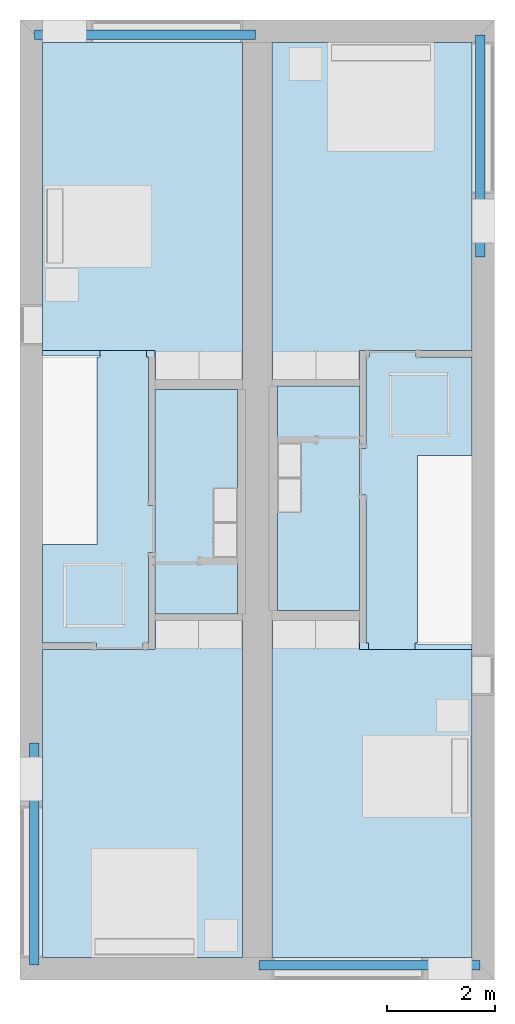
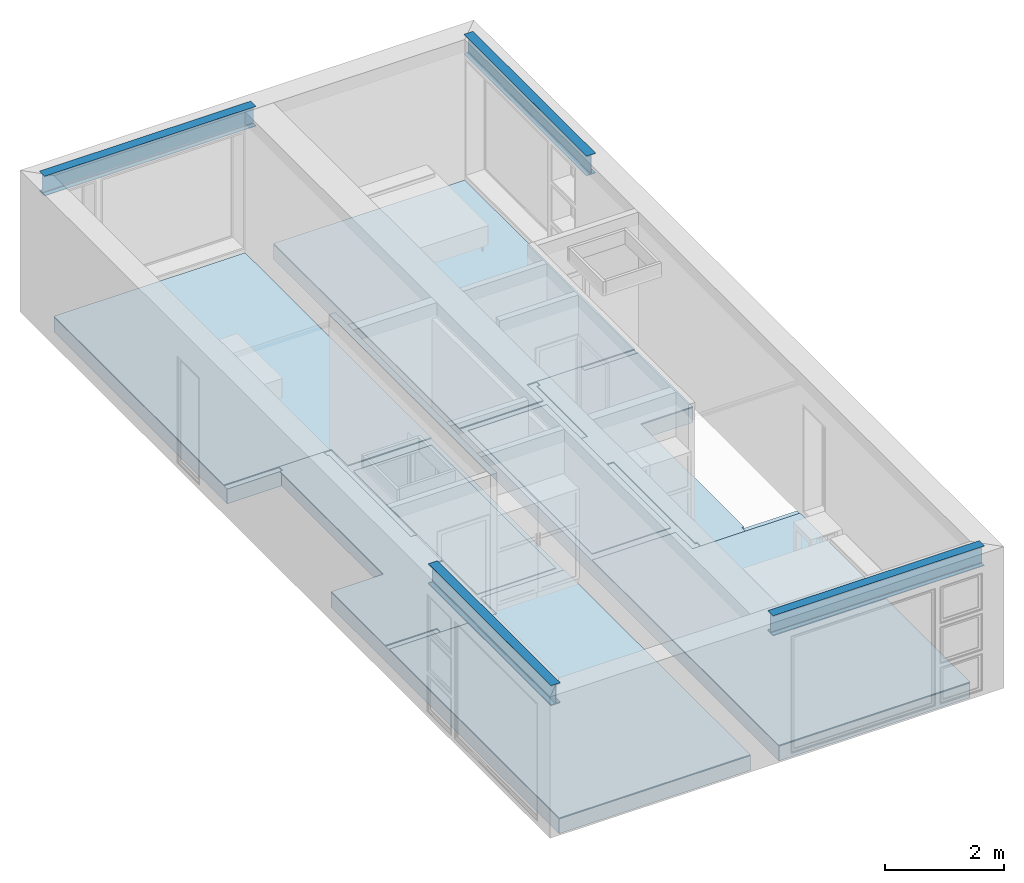
# One storey, part 1 of 14: 10 slabs, 4 beams.
"""IFC2X3 building model written with IfcOpenShell, lengths in metres."""

import ifcopenshell
import ifcopenshell.guid

model = None  # the IFC model being written
_history = None  # IfcOwnerHistory: only IFC2X3 demands one
_inside = {}  # id of a spatial element -> (the spatial element, [elements in it])
_under = {}  # id of a project, library or spatial element -> (it, [spatial elements below it])
_declared = {}  # id of a project -> (the project, [libraries it declares])
_typed = {}  # id of a type object -> (the type object, [elements of that type])
_made_of = {}  # id of a material, layer set ... -> (it, [elements and type objects made of it])


def new_model(schema):
    """Start an empty IFC model of exactly this schema.

    Asked for "IFC4X3", IfcOpenShell would pick the latest addendum, in which some entities
    have other attributes; the version numbers below select the first issue.
    IFC2X3 requires an IfcOwnerHistory on every rooted entity: one is made here for all.
    """
    global model, _history
    if schema == "IFC4X3":
        model = ifcopenshell.file(schema_version=(4, 3, 0, 0))
    else:
        model = ifcopenshell.file(schema=schema)
    _inside.clear()
    _under.clear()
    _declared.clear()
    _typed.clear()
    _made_of.clear()
    _history = None
    if model.schema == "IFC2X3":
        org = make("IfcOrganization", Name="unknown")
        user = make(
            "IfcPersonAndOrganization",
            ThePerson=make("IfcPerson", FamilyName="unknown"),
            TheOrganization=org,
        )
        app = make(
            "IfcApplication",
            ApplicationDeveloper=org,
            Version="unknown",
            ApplicationFullName="unknown",
            ApplicationIdentifier="unknown",
        )
        _history = make(
            "IfcOwnerHistory",
            OwningUser=user,
            OwningApplication=app,
            ChangeAction="ADDED",
            CreationDate=0,
        )
    return model


def make(cls, **values):
    """One entity of the class cls with the attributes given. An attribute that is None is left unset."""
    return model.create_entity(
        cls, **{name: value for name, value in values.items() if value is not None}
    )


def entity(cls, *values):
    """Any entity or typed value of the class cls, its attributes in the order of the schema. None: left unset."""
    e = model.create_entity(cls)
    for i, value in enumerate(values):
        if value is not None:
            e[i] = value
    return e


def rooted(cls, **values):
    """An entity with a GlobalId (a new one), such as an element, a storey or a relation."""
    return make(cls, GlobalId=ifcopenshell.guid.new(), OwnerHistory=_history, **values)


def si_unit(unit_type, name, prefix=None):
    """IfcSIUnit, for example si_unit("LENGTHUNIT", "METRE", prefix="MILLI")."""
    return make("IfcSIUnit", UnitType=unit_type, Prefix=prefix, Name=name)


def converted_unit(unit_type, name, factor, base, dimensions=None, offset=None):
    """IfcConversionBasedUnit, such as the inch: factor (a typed value) times the base unit."""
    return make(
        "IfcConversionBasedUnit"
        if offset is None
        else "IfcConversionBasedUnitWithOffset",
        ConversionOffset=offset,
        Dimensions=None
        if dimensions is None
        else entity("IfcDimensionalExponents", *dimensions),
        UnitType=unit_type,
        Name=name,
        ConversionFactor=make(
            "IfcMeasureWithUnit", ValueComponent=factor, UnitComponent=base
        ),
    )


def assignment(units):
    """IfcUnitAssignment: the units of a project."""
    return None if units is None else make("IfcUnitAssignment", Units=units)


def point(xyz):
    """IfcCartesianPoint."""
    return None if xyz is None else make("IfcCartesianPoint", Coordinates=xyz)


def direction(xyz):
    """IfcDirection."""
    return None if xyz is None else make("IfcDirection", DirectionRatios=xyz)


def frame(location, z_axis=None, x_axis=None):
    """IfcAxis2Placement3D, a coordinate frame: its origin and axes. An axis left out is left unset."""
    return make(
        "IfcAxis2Placement3D",
        Location=point(location),
        Axis=direction(z_axis),
        RefDirection=direction(x_axis),
    )


def frame_2d(location, x_axis=None):
    """IfcAxis2Placement2D, a coordinate frame in the plane: its origin and x axis."""
    return make(
        "IfcAxis2Placement2D", Location=point(location), RefDirection=direction(x_axis)
    )


def origin():
    """The frame at (0, 0, 0) with its axes left unset."""
    return frame((0.0, 0.0, 0.0))


def place(relative_to, where):
    """IfcLocalPlacement: puts the frame where relative to a parent placement (None: the world)."""
    return make(
        "IfcLocalPlacement", PlacementRelTo=relative_to, RelativePlacement=where
    )


def context(
    kind, dimensions, precision=None, world=None, true_north=None, identifier=None
):
    """IfcGeometricRepresentationContext, for example the 3D "Model" context."""
    return make(
        "IfcGeometricRepresentationContext",
        ContextIdentifier=identifier,
        ContextType=kind,
        CoordinateSpaceDimension=dimensions,
        Precision=precision,
        WorldCoordinateSystem=world,
        TrueNorth=true_north,
    )


def project(units=None, contexts=None):
    """IfcProject with its units and contexts."""
    return rooted(
        "IfcProject",
        Name="project",
        RepresentationContexts=contexts,
        UnitsInContext=assignment(units),
    )


def spatial(cls, under=None, at=None, **own):
    """A site, building, storey or space (cls), placed at a placement, below another one or the project."""
    s = rooted(cls, ObjectPlacement=at, **own)
    if under is not None:
        _under.setdefault(under.id(), (under, []))[1].append(s)
    return s


def polyline(points):
    """IfcPolyline through the points."""
    return make("IfcPolyline", Points=[point(p) for p in points])


def circle_curve(where, radius):
    """IfcCircle in the frame where."""
    return make("IfcCircle", Position=where, Radius=radius)


def parameter(value):
    """IfcParameterValue: where a trimmed curve begins or ends, as a parameter of its basis curve."""
    return model.create_entity("IfcParameterValue", value)


def trimmed(basis, trim1, trim2, sense, master):
    """IfcTrimmedCurve: the piece of a basis curve between two trims."""
    return make(
        "IfcTrimmedCurve",
        BasisCurve=basis,
        Trim1=trim1,
        Trim2=trim2,
        SenseAgreement=sense,
        MasterRepresentation=master,
    )


def segment(curve, same_sense, transition):
    """IfcCompositeCurveSegment."""
    return make(
        "IfcCompositeCurveSegment",
        Transition=transition,
        SameSense=same_sense,
        ParentCurve=curve,
    )


def composite_curve(segments, self_intersect=None):
    """IfcCompositeCurve: segments joined end to end."""
    return make("IfcCompositeCurve", Segments=segments, SelfIntersect=self_intersect)


def profile(cls, at=None, kind="AREA", **sizes):
    """A parametric profile (cls). Its sizes go by their IFC names, for example OverallWidth=200.0."""
    return make(cls, ProfileType=kind, Position=at, **sizes)


def rectangle(**sizes):
    """IfcRectangleProfileDef."""
    return profile("IfcRectangleProfileDef", **sizes)


def outline(outer, holes=None, kind="AREA"):
    """IfcArbitraryClosedProfileDef: a profile drawn as a closed curve; with holes, ...WithVoids."""
    if holes is None:
        return make("IfcArbitraryClosedProfileDef", ProfileType=kind, OuterCurve=outer)
    return make(
        "IfcArbitraryProfileDefWithVoids",
        ProfileType=kind,
        OuterCurve=outer,
        InnerCurves=holes,
    )


def extrude(swept, where, along, depth):
    """IfcExtrudedAreaSolid: the profile swept, set in the frame where, extruded along a direction by depth."""
    return make(
        "IfcExtrudedAreaSolid",
        SweptArea=swept,
        Position=where,
        ExtrudedDirection=direction(along),
        Depth=depth,
    )


def shape(context_of_items, identifier, shape_type, items):
    """IfcShapeRepresentation: the items that make up one representation, for example the "Body"."""
    return make(
        "IfcShapeRepresentation",
        ContextOfItems=context_of_items,
        RepresentationIdentifier=identifier,
        RepresentationType=shape_type,
        Items=items,
    )


def material(Name=None, Category=None):
    """IfcMaterial."""
    return make("IfcMaterial", Name=Name, Category=Category)


def layer(
    of_material, thickness, ventilated=None, Name=None, Category=None, Priority=None
):
    """IfcMaterialLayer: one layer of a wall or slab, of a material (None: an air gap)."""
    return make(
        "IfcMaterialLayer",
        Material=of_material,
        LayerThickness=thickness,
        IsVentilated=ventilated,
        Name=Name,
        Category=Category,
        Priority=Priority,
    )


def layer_set(layers, Name=None):
    """IfcMaterialLayerSet."""
    return make("IfcMaterialLayerSet", MaterialLayers=layers, LayerSetName=Name)


def layer_usage(for_layer_set, set_direction, sense, offset, extent=None):
    """IfcMaterialLayerSetUsage: how a layer set lies in its element."""
    return make(
        "IfcMaterialLayerSetUsage",
        ForLayerSet=for_layer_set,
        LayerSetDirection=set_direction,
        DirectionSense=sense,
        OffsetFromReferenceLine=offset,
        ReferenceExtent=extent,
    )


def made_of(thing, what):
    """Note that an element or type object is made of a material, layer set ...; save() writes the relation."""
    if what is not None:
        _made_of.setdefault(what.id(), (what, []))[1].append(thing)
    return thing


def element(
    cls,
    number,
    at=None,
    inside=None,
    cuts=None,
    type_object=None,
    material=None,
    context=None,
    identifier="Body",
    shape_type=None,
    held_by="IfcProductDefinitionShape",
    body=None,
    shapes=None,
    **own,
):
    """One element of the class cls, such as IfcWall. Its Tag is "e" and its number.

    at: its placement. inside: the storey or other place that contains it. cuts: it is an
    opening in that element (IfcRelVoidsElement). A single representation is given by context,
    identifier, shape_type and body (its items); several are given by shapes. held_by: the class
    of the entity that holds the representations. save() writes the other relations.
    """
    e = rooted(cls, Tag="e%d" % number, ObjectPlacement=at, **own)
    if body is not None:
        shapes = [shape(context, identifier, shape_type, body)]
    if shapes is not None:
        e.Representation = make(held_by, Representations=shapes)
    if inside is not None:
        _inside.setdefault(inside.id(), (inside, []))[1].append(e)
    if cuts is not None:
        rooted(
            "IfcRelVoidsElement", RelatingBuildingElement=cuts, RelatedOpeningElement=e
        )
    if type_object is not None:
        _typed.setdefault(type_object.id(), (type_object, []))[1].append(e)
    return made_of(e, material)


def aggregate(whole, parts):
    """IfcRelAggregates: a whole, such as a stair, and the parts it consists of."""
    return rooted("IfcRelAggregates", RelatingObject=whole, RelatedObjects=parts)


def save(model, path):
    """Write the relations noted so far, then the file.

    IfcRelAggregates (storeys below a building ...), IfcRelContainedInSpatialStructure (elements
    in a storey), IfcRelDefinesByType, IfcRelAssociatesMaterial and IfcRelDeclares: one each for
    every whole, place, type object, material and project.
    """
    for whole, parts in _under.values():
        aggregate(whole, parts)
    for where, things in _inside.values():
        rooted(
            "IfcRelContainedInSpatialStructure",
            RelatedElements=things,
            RelatingStructure=where,
        )
    for kind, things in _typed.values():
        rooted("IfcRelDefinesByType", RelatedObjects=things, RelatingType=kind)
    for what, things in _made_of.values():
        rooted("IfcRelAssociatesMaterial", RelatedObjects=things, RelatingMaterial=what)
    for by, libraries in _declared.values():
        rooted("IfcRelDeclares", RelatingContext=by, RelatedDefinitions=libraries)
    model.write(path)


model = new_model("IFC2X3")

# Units and contexts
model_context = context("Model", 3, precision=1e-09, world=origin())
plan_context = context("Plan", 3, precision=1e-09, world=origin())
ifc_project = project(units=[si_unit("LENGTHUNIT", "METRE"), si_unit("AREAUNIT", "SQUARE_METRE"), si_unit("VOLUMEUNIT", "CUBIC_METRE"), converted_unit("PLANEANGLEUNIT", "DEGREE", entity("IfcRatioMeasure", 0.01745329251994328), si_unit("PLANEANGLEUNIT", "RADIAN"), dimensions=[0, 0, 0, 0, 0, 0, 0]), si_unit("TIMEUNIT", "SECOND")], contexts=[model_context, plan_context])

# Site, building, storey
site_placement = place(None, origin())
site = spatial("IfcSite", under=ifc_project, at=site_placement, CompositionType="ELEMENT")
building_placement = place(site_placement, origin())
building = spatial("IfcBuilding", under=site, at=building_placement, CompositionType="ELEMENT")
storey_placement = place(building_placement, frame((0.0, 0.0, 3.100000000000378)))
storey = spatial("IfcBuildingStorey", under=building, at=storey_placement, Name="Level 2", CompositionType="ELEMENT", Elevation=3.100000000000378)

# Beams
ifc_material_1 = material(Name="Metal - Steel - 345 MPa")
beam_1_placement = place(storey_placement, frame((0.2666128795750488, -13.40172007136963, 2.89999999999983), z_axis=(0.0, 0.0, 1.0), x_axis=(-1.0, 0.0, 0.0)))
element("IfcBeam", 1, at=beam_1_placement, inside=storey, material=ifc_material_1, context=model_context, shape_type="SweptSolid", body=[
    extrude(outline(composite_curve([segment(polyline([(0.1906999999999978, -0.08900000000000018), (0.2034999999999992, -0.08900000000000018)]), True, "CONTINUOUS"), segment(polyline([(0.2034999999999992, -0.08900000000000018), (0.2034999999999992, 0.08900000000000004)]), True, "CONTINUOUS"), segment(polyline([(0.2034999999999992, 0.08900000000000004), (0.1906999999999978, 0.08900000000000004)]), True, "CONTINUOUS"), segment(polyline([(0.1906999999999978, 0.08900000000000004), (0.1906999999999978, 0.02104999999999999)]), True, "CONTINUOUS"), segment(trimmed(circle_curve(frame_2d((0.1734999999999985, 0.02104999999999992), x_axis=(1.0, 0.0)), 0.0172), [parameter(269.9999999999999)], [parameter(359.9999999999997)], True, "PARAMETER"), False, "CONTINUOUS"), segment(polyline([(0.1734999999999985, 0.003849999999999937), (-0.1735000000000017, 0.003849999999999937)]), True, "CONTINUOUS"), segment(trimmed(circle_curve(frame_2d((-0.1735000000000017, 0.02104999999999992), x_axis=(0.0, -1.0)), 0.0172), [parameter(269.9999999999999)], [parameter(359.9999999999999)], True, "PARAMETER"), False, "CONTINUOUS"), segment(polyline([(-0.1907000000000021, 0.02104999999999999), (-0.1907000000000021, 0.08900000000000004)]), True, "CONTINUOUS"), segment(polyline([(-0.1907000000000021, 0.08900000000000004), (-0.2035000000000014, 0.08900000000000004)]), True, "CONTINUOUS"), segment(polyline([(-0.2035000000000014, 0.08900000000000007), (-0.2035000000000014, -0.08899999999999963)]), True, "CONTINUOUS"), segment(polyline([(-0.2035000000000014, -0.08899999999999963), (-0.1907000000000021, -0.08899999999999963)]), True, "CONTINUOUS"), segment(polyline([(-0.1907000000000021, -0.08899999999999963), (-0.1907000000000021, -0.02105000000000012)]), True, "CONTINUOUS"), segment(trimmed(circle_curve(frame_2d((-0.1735000000000017, -0.02105000000000016), x_axis=(-1.0, 0.0)), 0.0172), [parameter(269.9999999999999)], [parameter(0.0)], True, "PARAMETER"), False, "CONTINUOUS"), segment(polyline([(-0.1735000000000017, -0.00385000000000014), (0.1734999999999985, -0.00385000000000014)]), True, "CONTINUOUS"), segment(trimmed(circle_curve(frame_2d((0.1734999999999985, -0.02105000000000016), x_axis=(0.0, 1.0)), 0.0172), [parameter(269.9999999999999)], [parameter(5.088887490341632e-14)], True, "PARAMETER"), False, "CONTINUOUS"), segment(polyline([(0.1906999999999978, -0.02105000000000012), (0.1906999999999978, -0.08900000000000018)]), True, "CONTINUOUS")], self_intersect=False)), frame((0.0, 4.121279928630347, -0.2035000000000068), z_axis=(0.0, -1.0, 0.0), x_axis=(0.0, 0.0, -1.0)), (0.0, 0.0, 1.0), 4.121279928630352),
])
beam_2_placement = place(storey_placement, frame((4.428954328744266, -17.52876686297367, 2.89999999999983), z_axis=(0.0, 0.0, 1.0), x_axis=(0.0, -1.0, 0.0)))
element("IfcBeam", 2, at=beam_2_placement, inside=storey, material=ifc_material_1, context=model_context, shape_type="SweptSolid", body=[
    extrude(outline(composite_curve([segment(polyline([(-0.08900000000000359, -0.1907), (-0.08900000000000359, -0.2035000000000014)]), True, "CONTINUOUS"), segment(polyline([(-0.08900000000000359, -0.2035000000000014), (0.0889999999999971, -0.2035000000000014)]), True, "CONTINUOUS"), segment(polyline([(0.0889999999999971, -0.2035000000000014), (0.0889999999999971, -0.1907)]), True, "CONTINUOUS"), segment(polyline([(0.0889999999999971, -0.1907), (0.02104999999999738, -0.1907)]), True, "CONTINUOUS"), segment(trimmed(circle_curve(frame_2d((0.02104999999999738, -0.1735000000000007), x_axis=(0.0, -1.0)), 0.0172), [parameter(269.9999999999999)], [parameter(359.9999999999997)], True, "PARAMETER"), False, "CONTINUOUS"), segment(polyline([(0.003849999999996959, -0.1735000000000007), (0.003849999999996959, 0.1734999999999995)]), True, "CONTINUOUS"), segment(trimmed(circle_curve(frame_2d((0.02104999999999738, 0.1734999999999995), x_axis=(-1.0, 0.0)), 0.0172), [parameter(269.9999999999999)], [parameter(359.9999999999999)], True, "PARAMETER"), False, "CONTINUOUS"), segment(polyline([(0.02104999999999522, 0.1907), (0.0889999999999971, 0.1907)]), True, "CONTINUOUS"), segment(polyline([(0.0889999999999971, 0.1907), (0.0889999999999971, 0.2034999999999992)]), True, "CONTINUOUS"), segment(polyline([(0.0889999999999971, 0.2034999999999992), (-0.08900000000000359, 0.2034999999999992)]), True, "CONTINUOUS"), segment(polyline([(-0.08900000000000359, 0.2034999999999992), (-0.08900000000000359, 0.1907)]), True, "CONTINUOUS"), segment(polyline([(-0.08900000000000359, 0.1907), (-0.02105000000000388, 0.1907)]), True, "CONTINUOUS"), segment(trimmed(circle_curve(frame_2d((-0.02105000000000388, 0.1734999999999995), x_axis=(0.0, 1.0)), 0.0172), [parameter(269.9999999999999)], [parameter(0.0)], True, "PARAMETER"), False, "CONTINUOUS"), segment(polyline([(-0.003850000000003457, 0.1734999999999995), (-0.003850000000003457, -0.1735000000000007)]), True, "CONTINUOUS"), segment(trimmed(circle_curve(frame_2d((-0.02105000000000388, -0.1735000000000007), x_axis=(1.0, 0.0)), 0.0172), [parameter(269.9999999999999)], [parameter(5.088887490341632e-14)], True, "PARAMETER"), False, "CONTINUOUS"), segment(polyline([(-0.02105000000000388, -0.1907), (-0.08900000000000359, -0.1907)]), True, "CONTINUOUS")], self_intersect=False)), frame((0.0, 0.0, -0.2035000000000046), z_axis=(0.0, -1.0, 0.0), x_axis=(1.0, 0.0, 0.0)), (0.0, 0.0, -1.0), 4.100000000000001),
])
beam_3_placement = place(storey_placement, frame((4.371045671255766, -0.2712331370263279, 2.89999999999983), z_axis=(0.0, 0.0, 1.0), x_axis=(0.0, 1.0, 0.0)))
element("IfcBeam", 3, at=beam_3_placement, inside=storey, material=ifc_material_1, context=model_context, shape_type="SweptSolid", body=[
    extrude(outline(composite_curve([segment(polyline([(0.1906999999999978, -0.08900000000000008), (0.2034999999999992, -0.08900000000000008)]), True, "CONTINUOUS"), segment(polyline([(0.2034999999999992, -0.08900000000000008), (0.2034999999999992, 0.08900000000000013)]), True, "CONTINUOUS"), segment(polyline([(0.2034999999999992, 0.08900000000000013), (0.1906999999999978, 0.08900000000000013)]), True, "CONTINUOUS"), segment(polyline([(0.1906999999999978, 0.08900000000000013), (0.1906999999999978, 0.02105000000000009)]), True, "CONTINUOUS"), segment(trimmed(circle_curve(frame_2d((0.1734999999999985, 0.02105000000000002), x_axis=(1.0, 0.0)), 0.0172), [parameter(269.9999999999999)], [parameter(359.9999999999997)], True, "PARAMETER"), False, "CONTINUOUS"), segment(polyline([(0.1734999999999985, 0.003850000000000039), (-0.1735000000000017, 0.003850000000000039)]), True, "CONTINUOUS"), segment(trimmed(circle_curve(frame_2d((-0.1735000000000017, 0.02105000000000002), x_axis=(0.0, -1.0)), 0.0172), [parameter(269.9999999999999)], [parameter(359.9999999999999)], True, "PARAMETER"), False, "CONTINUOUS"), segment(polyline([(-0.1907000000000021, 0.02105000000000009), (-0.1907000000000021, 0.08900000000000013)]), True, "CONTINUOUS"), segment(polyline([(-0.1907000000000021, 0.08900000000000013), (-0.2035000000000014, 0.08900000000000013)]), True, "CONTINUOUS"), segment(polyline([(-0.2035000000000014, 0.08900000000000016), (-0.2035000000000014, -0.08899999999999954)]), True, "CONTINUOUS"), segment(polyline([(-0.2035000000000014, -0.08899999999999954), (-0.1907000000000021, -0.08899999999999954)]), True, "CONTINUOUS"), segment(polyline([(-0.1907000000000021, -0.08899999999999954), (-0.1907000000000021, -0.02105000000000002)]), True, "CONTINUOUS"), segment(trimmed(circle_curve(frame_2d((-0.1735000000000017, -0.02105000000000006), x_axis=(-1.0, 0.0)), 0.0172), [parameter(269.9999999999999)], [parameter(0.0)], True, "PARAMETER"), False, "CONTINUOUS"), segment(polyline([(-0.1735000000000017, -0.003850000000000038), (0.1734999999999985, -0.003850000000000038)]), True, "CONTINUOUS"), segment(trimmed(circle_curve(frame_2d((0.1734999999999985, -0.02105000000000006), x_axis=(0.0, 1.0)), 0.0172), [parameter(269.9999999999999)], [parameter(5.088887490341632e-14)], True, "PARAMETER"), False, "CONTINUOUS"), segment(polyline([(0.1906999999999978, -0.02105000000000002), (0.1906999999999978, -0.08900000000000008)]), True, "CONTINUOUS")], self_intersect=False)), frame((0.0, 4.1, -0.2035000000000068), z_axis=(0.0, -1.0, 0.0), x_axis=(0.0, 0.0, -1.0)), (0.0, 0.0, 1.0), 4.100000000000001),
])
beam_4_placement = place(storey_placement, frame((8.533387120424969, -4.398279928630386, 2.89999999999983)))
element("IfcBeam", 4, at=beam_4_placement, inside=storey, material=ifc_material_1, context=model_context, shape_type="SweptSolid", body=[
    extrude(outline(composite_curve([segment(polyline([(-0.08900000000000033, -0.1907), (-0.08900000000000033, -0.2035000000000014)]), True, "CONTINUOUS"), segment(polyline([(-0.08900000000000033, -0.2035000000000014), (0.08899999999999927, -0.2035000000000014)]), True, "CONTINUOUS"), segment(polyline([(0.08899999999999927, -0.2035000000000014), (0.08899999999999927, -0.1907)]), True, "CONTINUOUS"), segment(polyline([(0.08899999999999927, -0.1907), (0.02104999999999955, -0.1907)]), True, "CONTINUOUS"), segment(trimmed(circle_curve(frame_2d((0.02104999999999955, -0.1735000000000007), x_axis=(0.0, -1.0)), 0.0172), [parameter(269.9999999999999)], [parameter(359.9999999999997)], True, "PARAMETER"), False, "CONTINUOUS"), segment(polyline([(0.003849999999999125, -0.1735000000000007), (0.003849999999999125, 0.1734999999999995)]), True, "CONTINUOUS"), segment(trimmed(circle_curve(frame_2d((0.02104999999999955, 0.1734999999999995), x_axis=(-1.0, 0.0)), 0.0172), [parameter(269.9999999999999)], [parameter(359.9999999999999)], True, "PARAMETER"), False, "CONTINUOUS"), segment(polyline([(0.02104999999999955, 0.1907), (0.08899999999999927, 0.1907)]), True, "CONTINUOUS"), segment(polyline([(0.08899999999999927, 0.1907), (0.08899999999999927, 0.2034999999999992)]), True, "CONTINUOUS"), segment(polyline([(0.08899999999999927, 0.2034999999999992), (-0.08900000000000033, 0.2034999999999992)]), True, "CONTINUOUS"), segment(polyline([(-0.08900000000000033, 0.2034999999999992), (-0.08900000000000033, 0.1907)]), True, "CONTINUOUS"), segment(polyline([(-0.08900000000000033, 0.1907), (-0.02105000000000063, 0.1907)]), True, "CONTINUOUS"), segment(trimmed(circle_curve(frame_2d((-0.02105000000000063, 0.1734999999999995), x_axis=(0.0, 1.0)), 0.0172), [parameter(269.9999999999999)], [parameter(0.0)], True, "PARAMETER"), False, "CONTINUOUS"), segment(polyline([(-0.003850000000000208, 0.1734999999999995), (-0.003850000000000208, -0.1735000000000007)]), True, "CONTINUOUS"), segment(trimmed(circle_curve(frame_2d((-0.02105000000000063, -0.1735000000000007), x_axis=(1.0, 0.0)), 0.0172), [parameter(269.9999999999999)], [parameter(5.088887490341632e-14)], True, "PARAMETER"), False, "CONTINUOUS"), segment(polyline([(-0.02105000000000063, -0.1907), (-0.08900000000000033, -0.1907)]), True, "CONTINUOUS")], self_intersect=False)), frame((0.0, 0.0, -0.2035000000000046), z_axis=(0.0, -1.0, 0.0), x_axis=(1.0, 0.0, 0.0)), (0.0, 0.0, -1.0), 4.121279928630351),
])

# Slabs
ifc_material_2 = material(Name="Wood - Sheathing - plywood")
ifc_layer_1 = layer(ifc_material_2, 0.019)
ifc_material_3 = material(Name="Wood - Dimensional Lumber")
ifc_layer_2 = layer(ifc_material_3, 0.286)
ifc_layer_set_1 = layer_set([ifc_layer_1, ifc_layer_2], Name="Floor:Residential - Wood Joist with")
ifc_layer_usage_1 = layer_usage(ifc_layer_set_1, "AXIS3", "POSITIVE", 0.0)
slab_1_placement = place(storey_placement, frame((4.674999999999998, -17.383, -0.3050000000001818)))
element("IfcSlab", 5, at=slab_1_placement, inside=storey, material=ifc_layer_usage_1, Name="Floor:Residential - Wood Joist with", ObjectType="Floor:Residential - Wood Joist with", PredefinedType="FLOOR", context=model_context, shape_type="SweptSolid", body=[
    extrude(outline(polyline([(-1.854000000000013, 8.48299999999998), (-1.854000000000001, 0.8250000000000031), (-0.829600000000002, 0.8250000000000063), (-0.8295999999999966, -2.665999999999991), (-1.853999999999995, -2.665999999999995), (-1.853999999999986, -8.482999999999992), (1.853999999999987, -8.482999999999981), (1.853999999999986, 8.482999999999992), (-1.854000000000013, 8.48299999999998)])), frame((1.853999999999987, 8.482999999999992, 0.305), z_axis=(0.0, 0.0, -1.0), x_axis=(-1.0, 0.0, 0.0)), (0.0, 0.0, 1.0), 0.305),
])
slab_2_placement = place(storey_placement, frame((0.4169999999999994, -17.38299999999999, -0.3050000000001818)))
element("IfcSlab", 6, at=slab_2_placement, inside=storey, material=ifc_layer_usage_1, Name="Floor:Residential - Wood Joist with", ObjectType="Floor:Residential - Wood Joist with", PredefinedType="FLOOR", context=model_context, shape_type="SweptSolid", body=[
    extrude(outline(polyline([(-1.854000000000013, 8.48299999999998), (-1.853999999999986, -8.482999999999993), (1.853999999999987, -8.482999999999981), (1.853999999999987, -0.8250000000000085), (0.799599999999962, -0.8250000000000117), (0.7995999999999563, 2.665999999999988), (1.853999999999987, 2.665999999999991), (1.853999999999986, 8.482999999999993), (-1.854000000000013, 8.48299999999998)])), frame((1.853999999999987, 8.482999999999993, 0.305), z_axis=(0.0, 0.0, -1.0), x_axis=(-1.0, 0.0, 0.0)), (0.0, 0.0, 1.0), 0.305),
])
ifc_material_4 = material(Name="Ceramic Tile")
ifc_layer_3 = layer(ifc_material_4, 0.01)
ifc_material_5 = material(Name="Masonry - Grout")
ifc_layer_4 = layer(ifc_material_5, 0.003)
ifc_layer_set_2 = layer_set([ifc_layer_3, ifc_layer_4], Name="Floor:Finish Floor - Ceramic Tile")
ifc_layer_usage_2 = layer_usage(ifc_layer_set_2, "AXIS3", "POSITIVE", 0.0)
slab_3_placement = place(storey_placement, frame((4.769999999999986, -10.95000000000001, 0.0)))
element("IfcSlab", 7, at=slab_3_placement, inside=storey, material=ifc_layer_usage_2, Name="Floor:Finish Floor - Ceramic Tile", ObjectType="Floor:Finish Floor - Ceramic Tile", PredefinedType="FLOOR", context=model_context, shape_type="SweptSolid", body=[
    extrude(rectangle(XDim=4.160000000000009, YDim=1.524000000000014, at=frame_2d((0.0, 0.0), x_axis=(0.0, -1.0))), frame((0.7620000000000071, 2.080000000000005, 0.01299999999999975), z_axis=(0.0, 0.0, -1.0), x_axis=(-1.0, 0.0, 0.0)), (0.0, 0.0, 1.0), 0.01299999999999975),
])
slab_4_placement = place(storey_placement, frame((2.505999999999992, -11.01, 0.0)))
element("IfcSlab", 8, at=slab_4_placement, inside=storey, material=ifc_layer_usage_2, Name="Floor:Finish Floor - Ceramic Tile", ObjectType="Floor:Finish Floor - Ceramic Tile", PredefinedType="FLOOR", context=model_context, shape_type="SweptSolid", body=[
    extrude(rectangle(XDim=4.16, YDim=1.523999999999994, at=frame_2d((0.0, 0.0), x_axis=(0.0, -1.0))), frame((0.7619999999999968, 2.080000000000001, 0.01299999999999975), z_axis=(0.0, 0.0, -1.0), x_axis=(-1.0, 0.0, 0.0)), (0.0, 0.0, 1.0), 0.01299999999999975),
])
ifc_material_6 = material(Name="Wood - Flooring")
ifc_layer_5 = layer(ifc_material_6, 0.016)
ifc_material_7 = material(Name="Insulation / Thermal Barriers - Semi-rigid insulation")
ifc_layer_6 = layer(ifc_material_7, 0.003)
ifc_layer_set_3 = layer_set([ifc_layer_5, ifc_layer_6], Name="Floor:Finish Floor - Wood")
ifc_layer_usage_3 = layer_usage(ifc_layer_set_3, "AXIS3", "POSITIVE", 0.0)
slab_5_placement = place(storey_placement, frame((4.675, -6.666000000000003, 0.0)))
element("IfcSlab", 9, at=slab_5_placement, inside=storey, material=ifc_layer_usage_3, Name="Floor:Finish Floor - Wood", ObjectType="Floor:Finish Floor - Wood", PredefinedType="FLOOR", context=model_context, shape_type="SweptSolid", body=[
    extrude(outline(polyline([(-1.854000000000005, 3.124499999999986), (-1.853999999999995, -2.584499999999996), (0.2349999999999791, -2.58449999999999), (0.2349999999999791, -3.124499999999991), (1.853999999999994, -3.124499999999991), (1.853999999999994, 3.124499999999997), (-1.854000000000005, 3.124499999999986)])), frame((1.853999999999994, 3.124499999999991, 0.01900000000000001), z_axis=(0.0, 0.0, -1.0), x_axis=(-1.0, 0.0, 0.0)), (0.0, 0.0, 1.0), 0.01900000000000001),
])
slab_6_placement = place(storey_placement, frame((4.674999999999972, -17.383, 0.0)))
element("IfcSlab", 10, at=slab_6_placement, inside=storey, material=ifc_layer_usage_3, Name="Floor:Finish Floor - Wood", ObjectType="Floor:Finish Floor - Wood", PredefinedType="FLOOR", context=model_context, shape_type="SweptSolid", body=[
    extrude(outline(polyline([(-1.854000000000023, 2.576499999999997), (-1.853999999999994, -3.132499999999998), (1.854000000000005, -3.132499999999987), (1.853999999999995, 3.132499999999996), (0.2349999999999617, 3.132499999999996), (0.2349999999999617, 2.576499999999997), (-1.854000000000023, 2.576499999999997)])), frame((1.854000000000005, 3.132499999999998, 0.01900000000000001), z_axis=(0.0, 0.0, -1.0), x_axis=(-1.0, 0.0, 0.0)), (0.0, 0.0, 1.0), 0.01900000000000001),
])
slab_7_placement = place(storey_placement, frame((0.4169999999999994, -17.38299999999999, 0.0)))
element("IfcSlab", 11, at=slab_7_placement, inside=storey, material=ifc_layer_usage_3, Name="Floor:Finish Floor - Wood", ObjectType="Floor:Finish Floor - Wood", PredefinedType="FLOOR", context=model_context, shape_type="SweptSolid", body=[
    extrude(outline(polyline([(-1.853999999999981, -3.124499999999998), (1.853999999999992, -3.124499999999987), (1.853999999999992, 2.584499999999991), (-0.2350000000000067, 2.584499999999984), (-0.2350000000000067, 3.124499999999985), (-1.854000000000009, 3.124499999999985), (-1.853999999999981, -3.124499999999998)])), frame((1.853999999999992, 3.124499999999998, 0.01900000000000001), z_axis=(0.0, 0.0, -1.0), x_axis=(-1.0, 0.0, 0.0)), (0.0, 0.0, 1.0), 0.01900000000000001),
])
slab_8_placement = place(storey_placement, frame((6.294000000000013, -11.67400000000001, 0.0)))
element("IfcSlab", 12, at=slab_8_placement, inside=storey, material=ifc_layer_usage_3, Name="Floor:Finish Floor - Wood", ObjectType="Floor:Finish Floor - Wood", PredefinedType="FLOOR", context=model_context, shape_type="SweptSolid", body=[
    extrude(outline(polyline([(0.9205000000000149, 0.09061576492848053), (1.044499999999974, 0.09061576492848161), (1.044499999999972, 0.9546157649284801), (0.9204999999999943, 0.9546157649284801), (0.9204999999999889, 2.650000000000002), (0.8604999999999787, 2.650000000000002), (0.8604999999999787, 2.774000000000003), (-0.003500000000020862, 2.773999999999997), (-0.003500000000020862, 2.649999999999998), (-1.044499999999993, 2.649999999999991), (-1.044499999999988, 0.8249999999999976), (-0.03010000000000182, 0.8250000000000031), (-0.03009999999998233, -2.649999999999998), (0.01720000000000151, -2.649999999999998), (0.01720000000000259, -2.773999999999997), (0.8812000000000033, -2.773999999999991), (0.8812000000000022, -2.649999999999989), (0.9205000000000235, -2.649999999999989), (0.9205000000000149, 0.09061576492848053)])), frame((1.044499999999974, 2.773999999999997, 0.01900000000000001), z_axis=(0.0, 0.0, -1.0), x_axis=(-1.0, 0.0, 0.0)), (0.0, 0.0, 1.0), 0.01900000000000001),
])
slab_9_placement = place(storey_placement, frame((0.4169999999999989, -6.666000000000008, 0.0)))
element("IfcSlab", 13, at=slab_9_placement, inside=storey, material=ifc_layer_usage_3, Name="Floor:Finish Floor - Wood", ObjectType="Floor:Finish Floor - Wood", PredefinedType="FLOOR", context=model_context, shape_type="SweptSolid", body=[
    extrude(outline(polyline([(1.853999999999995, 3.124500000000004), (-1.854000000000005, 3.124499999999991), (-1.853999999999995, -3.124500000000002), (-0.235000000000004, -3.124499999999999), (-0.235000000000004, -2.584499999999999), (1.853999999999996, -2.584499999999999), (1.853999999999995, 3.124500000000004)])), frame((1.853999999999996, 3.124500000000002, 0.01900000000000001), z_axis=(0.0, 0.0, -1.0), x_axis=(-1.0, 0.0, 0.0)), (0.0, 0.0, 1.0), 0.01900000000000001),
])
slab_10_placement = place(storey_placement, frame((0.4169999999999994, -11.674, 0.0)))
element("IfcSlab", 14, at=slab_10_placement, inside=storey, material=ifc_layer_usage_3, Name="Floor:Finish Floor - Wood", ObjectType="Floor:Finish Floor - Wood", PredefinedType="FLOOR", context=model_context, shape_type="SweptSolid", body=[
    extrude(outline(polyline([(-0.9205000000000011, -0.1060511785105842), (-1.0445, -0.1060511785105842), (-1.0445, -0.9700511785105828), (-0.9205000000000011, -0.9700511785105828), (-0.9205000000000011, -2.649999999999998), (-0.8204999999999938, -2.649999999999998), (-0.8204999999999935, -2.774), (0.04350000000000635, -2.773999999999995), (0.04350000000000608, -2.649999999999998), (1.0445, -2.649999999999993), (1.0445, -0.8249999999999998), (0.03009999999999938, -0.825000000000002), (0.03009999999999126, 2.649999999999999), (-0.02179999999999559, 2.649999999999999), (-0.02179999999999613, 2.773999999999999), (-0.8857999999999965, 2.773999999999997), (-0.885799999999996, 2.650000000000002), (-0.9205000000000011, 2.650000000000002), (-0.9205000000000011, -0.1060511785105842)])), frame((1.0445, 2.774, 0.01900000000000001), z_axis=(0.0, 0.0, -1.0), x_axis=(-1.0, 0.0, 0.0)), (0.0, 0.0, 1.0), 0.01900000000000001),
])

save(model, "model.ifc")
